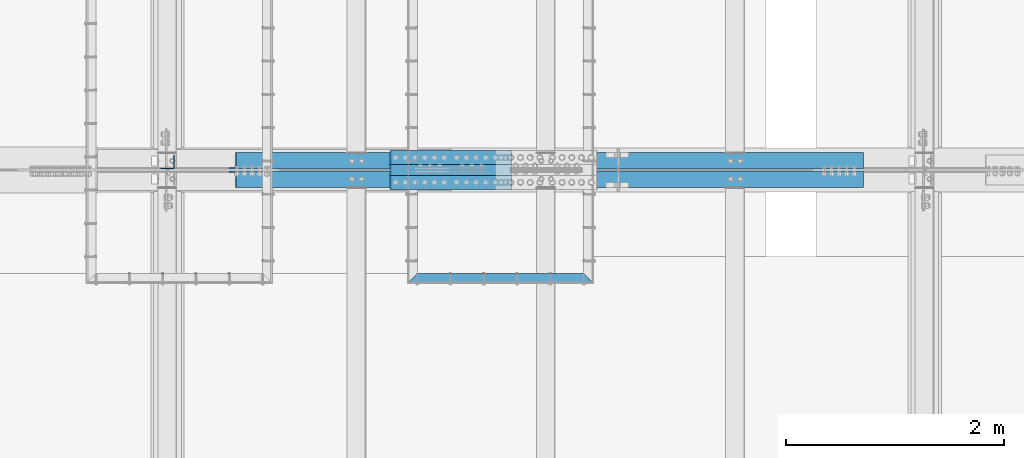
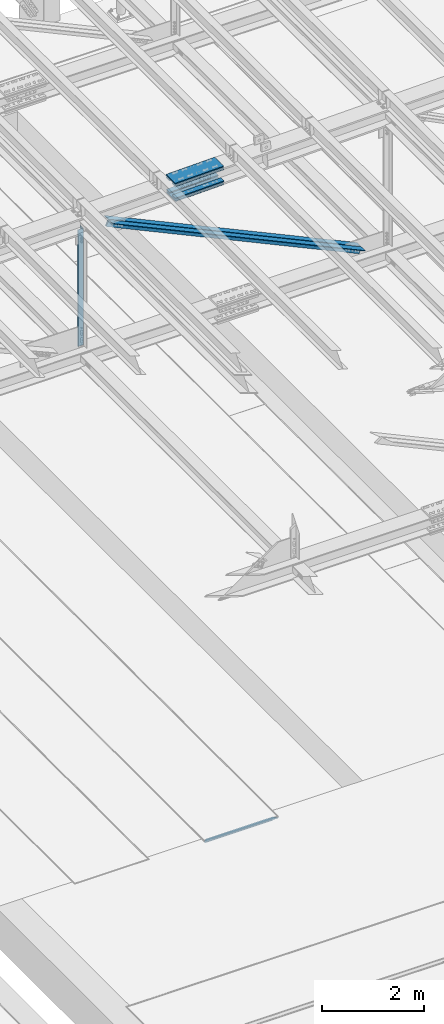
# One storey, part 1890 of 3843: 8 beams, 2 members, 5 elements without a shape of their own.
"""IFC2X3 building model written with IfcOpenShell, lengths in millimetres."""

from ifc_helpers import new_model, si_unit, frame, origin_with_axes, place, context, subcontext, project, spatial, faceted_brep, material, type_object, element, aggregate, save


model = new_model("IFC2X3")

# Units and contexts
model_context = context("Model", 3, precision=1e-05, world=origin_with_axes())
body_context = subcontext(model_context, "Body", "Model", "MODEL_VIEW")
ifc_project = project(units=[si_unit("LENGTHUNIT", "METRE", prefix="MILLI"), si_unit("AREAUNIT", "SQUARE_METRE"), si_unit("VOLUMEUNIT", "CUBIC_METRE"), si_unit("MASSUNIT", "GRAM", prefix="KILO"), si_unit("TIMEUNIT", "SECOND"), si_unit("PLANEANGLEUNIT", "RADIAN"), si_unit("SOLIDANGLEUNIT", "STERADIAN"), si_unit("THERMODYNAMICTEMPERATUREUNIT", "DEGREE_CELSIUS"), si_unit("LUMINOUSINTENSITYUNIT", "LUMEN")], contexts=[model_context])

# Site, building, storey
site_placement = place(None, origin_with_axes())
site = spatial("IfcSite", under=ifc_project, at=site_placement, CompositionType="ELEMENT")
building_placement = place(site_placement, origin_with_axes())
building = spatial("IfcBuilding", under=site, at=building_placement, Name="Undefined", CompositionType="ELEMENT")
storey_placement = place(building_placement, origin_with_axes())
storey = spatial("IfcBuildingStorey", under=building, at=storey_placement, Name="Undefined", CompositionType="ELEMENT", Elevation=0.0)

# Assembly, beam
assembly_1_placement = place(storey_placement, origin_with_axes())
assembly_1 = element("IfcElementAssembly", 1, at=assembly_1_placement, inside=storey, Name="EMBED_ANGLE", AssemblyPlace="NOTDEFINED", PredefinedType="RIGID_FRAME")
ifc_material_1 = material(Name="STEEL/A36")
beam_type_1 = type_object("IfcBeamType", Name="L3-1/2X3-1/2X5/16", PredefinedType="NOTDEFINED")
beam_1_placement = place(assembly_1_placement, frame((51194.525441805, 66281.427, 30410.15), z_axis=(0.0, -1.0, 0.0), x_axis=(1.0, 0.0, 0.0)))
beam_1 = element("IfcBeam", 2, at=beam_1_placement, type_object=beam_type_1, material=ifc_material_1, Name="EMBED_ANGLE", ObjectType="L3-1/2X3-1/2X5/16", context=body_context, shape_type="Brep", body=[
    faceted_brep([(88.8999999971129, 44.4500000000007, -44.4499999999971), (-3.63797880709171e-12, 44.4499999999971, 44.4500000000007), (1701.73653678348, 44.4500000000007, 44.4499999912659), (1612.83653598122, 44.4500000000007, -44.4500000082771), (-3.63797880709171e-12, 36.5124999999971, 44.4500000000007), (1701.73653678348, 36.5125000000007, 44.4499999912659), (80.9624999971129, 36.5125000000007, -36.5124999999971), (1620.77403605285, 36.5125000000007, -36.5125000083208), (80.9624999971129, -44.4500000000007, -36.5124999999971), (1620.77403605285, -44.4500000000007, -36.5125000083208), (88.8999999971129, -44.4500000000007, -44.4499999999971), (1612.83653598122, -44.4500000000007, -44.4500000082771)], [[[0, 1, 2, 3]], [[1, 4, 5, 2]], [[4, 6, 7, 5]], [[6, 8, 9, 7]], [[8, 10, 11, 9]], [[10, 0, 3, 11]], [[5, 7, 9, 11, 3, 2]], [[10, 8, 6, 4, 1, 0]]]),
])
aggregate(assembly_1, [beam_1])

# Assembly, beams
assembly_2_placement = place(storey_placement, origin_with_axes())
assembly_2 = element("IfcElementAssembly", 3, at=assembly_2_placement, inside=storey, Name="BEAM", AssemblyPlace="NOTDEFINED", PredefinedType="RIGID_FRAME")
ifc_material_2 = material(Name="STEEL/A572-50")
beam_type_2 = type_object("IfcBeamType", PredefinedType="NOTDEFINED")
beam_2_placement = place(assembly_2_placement, frame((51036.3131698347, 67386.2, 45743.4514056909), z_axis=(0.0, -1.0, 0.0), x_axis=(0.999702328324067, 0.0, 0.0243978430079076)))
beam_2 = element("IfcBeam", 4, at=beam_2_placement, type_object=beam_type_2, material=ifc_material_2, Name="PLATE", context=body_context, shape_type="Brep", body=[
    faceted_brep([(-4.36557456851006e-11, 12.7000000000116, -63.5), (-4.36557456851006e-11, 12.7000000000116, 63.5), (1104.90000001677, 12.7000000017251, 63.5), (1104.90000001677, 12.7000000017251, -63.5), (1.45519152283669e-11, -12.700000000008, 63.5), (1104.90000001682, -12.6999999982909, 63.5), (1.45519152283669e-11, -12.700000000008, -63.5), (1104.90000001682, -12.6999999982909, -63.5)], [[[0, 1, 2, 3]], [[1, 4, 5, 2]], [[4, 6, 7, 5]], [[6, 0, 3, 7]], [[5, 7, 3, 2]], [[6, 4, 1, 0]]]),
])
beam_3_placement = place(assembly_2_placement, frame((51036.3131698347, 67157.6, 45743.4514056909), z_axis=(0.0, -1.0, 0.0), x_axis=(0.999702328324067, 0.0, 0.0243978430079076)))
beam_3 = element("IfcBeam", 5, at=beam_3_placement, type_object=beam_type_2, material=ifc_material_2, Name="PLATE", context=body_context, shape_type="Brep", body=[
    faceted_brep([(-4.36557456851006e-11, 12.7000000000116, -63.5), (-4.36557456851006e-11, 12.7000000000116, 63.5), (1104.90000001677, 12.7000000017251, 63.5), (1104.90000001677, 12.7000000017251, -63.5), (1.45519152283669e-11, -12.700000000008, 63.5), (1104.90000001682, -12.6999999982909, 63.5), (1.45519152283669e-11, -12.700000000008, -63.5), (1104.90000001682, -12.6999999982909, -63.5)], [[[0, 1, 2, 3]], [[1, 4, 5, 2]], [[4, 6, 7, 5]], [[6, 0, 3, 7]], [[5, 7, 3, 2]], [[6, 4, 1, 0]]]),
])
beam_4_placement = place(assembly_2_placement, frame((51043.5211675553, 67157.6, 45448.2698515432), z_axis=(0.0, -1.0, 0.0), x_axis=(0.999702328324067, 0.0, 0.0243978430079076)))
beam_4 = element("IfcBeam", 6, at=beam_4_placement, type_object=beam_type_2, material=ifc_material_2, Name="PLATE", context=body_context, shape_type="Brep", body=[
    faceted_brep([(-4.36557456851006e-11, 12.7000000000116, -63.5), (-4.36557456851006e-11, 12.7000000000116, 63.5), (1104.90000001677, 12.7000000017251, 63.5), (1104.90000001677, 12.7000000017251, -63.5), (1.45519152283669e-11, -12.700000000008, 63.5), (1104.90000001682, -12.6999999982909, 63.5), (1.45519152283669e-11, -12.700000000008, -63.5), (1104.90000001682, -12.6999999982909, -63.5)], [[[0, 1, 2, 3]], [[1, 4, 5, 2]], [[4, 6, 7, 5]], [[6, 0, 3, 7]], [[5, 7, 3, 2]], [[6, 4, 1, 0]]]),
])
beam_5_placement = place(assembly_2_placement, frame((51043.5211675553, 67386.2, 45448.2698515432), z_axis=(0.0, -1.0, 0.0), x_axis=(0.999702328324067, 0.0, 0.0243978430079076)))
beam_5 = element("IfcBeam", 7, at=beam_5_placement, type_object=beam_type_2, material=ifc_material_2, Name="PLATE", context=body_context, shape_type="Brep", body=[
    faceted_brep([(-4.36557456851006e-11, 12.7000000000116, -63.5), (-4.36557456851006e-11, 12.7000000000116, 63.5), (1104.90000001677, 12.7000000017251, 63.5), (1104.90000001677, 12.7000000017251, -63.5), (1.45519152283669e-11, -12.700000000008, 63.5), (1104.90000001682, -12.6999999982909, 63.5), (1.45519152283669e-11, -12.700000000008, -63.5), (1104.90000001682, -12.6999999982909, -63.5)], [[[0, 1, 2, 3]], [[1, 4, 5, 2]], [[4, 6, 7, 5]], [[6, 0, 3, 7]], [[5, 7, 3, 2]], [[6, 4, 1, 0]]]),
])
beam_type_3 = type_object("IfcBeamType", PredefinedType="NOTDEFINED")
beam_6_placement = place(assembly_2_placement, frame((52139.3758984562, 67271.9, 45832.3806058686), z_axis=(0.0, -1.0, 0.0), x_axis=(-0.999702328324067, 0.0, -0.024397843007905)))
beam_6 = element("IfcBeam", 8, at=beam_6_placement, type_object=beam_type_3, material=ifc_material_2, Name="PLATE", context=body_context, shape_type="Brep", body=[
    faceted_brep([(-1.45519152283669e-11, 12.7000000000025, -177.800000000003), (-1.45519152283669e-11, 12.7000000000025, 177.800000000003), (1104.90000001682, 12.7000000017051, 177.800000000003), (1104.90000001682, 12.7000000017051, -177.800000000003), (4.36557456851006e-11, -12.7000000000171, 177.800000000003), (1104.90000001686, -12.6999999983072, 177.800000000003), (4.36557456851006e-11, -12.7000000000171, -177.800000000003), (1104.90000001686, -12.6999999983072, -177.800000000003)], [[[0, 1, 2, 3]], [[1, 4, 5, 2]], [[4, 6, 7, 5]], [[6, 0, 3, 7]], [[5, 7, 3, 2]], [[6, 4, 1, 0]]]),
])
beam_7_placement = place(assembly_2_placement, frame((52149.6055654215, 67271.9, 45413.3330253169), z_axis=(0.0, -1.0, 0.0), x_axis=(-0.999702328324067, 0.0, -0.024397843007905)))
beam_7 = element("IfcBeam", 9, at=beam_7_placement, type_object=beam_type_3, material=ifc_material_2, Name="PLATE", context=body_context, shape_type="Brep", body=[
    faceted_brep([(-1.45519152283669e-11, 12.7000000000025, -177.800000000003), (-1.45519152283669e-11, 12.7000000000025, 177.800000000003), (1104.90000001682, 12.7000000017051, 177.800000000003), (1104.90000001682, 12.7000000017051, -177.800000000003), (4.36557456851006e-11, -12.7000000000171, 177.800000000003), (1104.90000001686, -12.6999999983072, 177.800000000003), (4.36557456851006e-11, -12.7000000000171, -177.800000000003), (1104.90000001686, -12.6999999983072, -177.800000000003)], [[[0, 1, 2, 3]], [[1, 4, 5, 2]], [[4, 6, 7, 5]], [[6, 0, 3, 7]], [[5, 7, 3, 2]], [[6, 4, 1, 0]]]),
])
aggregate(assembly_2, [beam_2, beam_3, beam_4, beam_6, beam_7, beam_5])

# Assembly, beam
assembly_3_placement = place(storey_placement, origin_with_axes())
assembly_3 = element("IfcElementAssembly", 10, at=assembly_3_placement, inside=storey, Name="ANGLE", AssemblyPlace="NOTDEFINED", PredefinedType="RIGID_FRAME")
beam_type_4 = type_object("IfcBeamType", Name="L5X5X3/8", PredefinedType="NOTDEFINED")
beam_8_placement = place(assembly_3_placement, frame((48996.6, 67344.925, 45545.3859130701), z_axis=(-1.0, 0.0, 0.0), x_axis=(0.0, 0.0, -1.0)))
beam_8 = element("IfcBeam", 11, at=beam_8_placement, type_object=beam_type_4, material=ifc_material_2, Name="ANGLE", ObjectType="L5X5X3/8", context=body_context, shape_type="Brep", body=[
    faceted_brep([(223.333405012316, 63.5, -63.500000000713), (223.333405012323, 63.5, 63.499999999287), (3028.11053135413, 63.5, 63.499999990323), (3028.11053135413, 63.5, -63.500000009677), (223.333405012323, 53.9750000000058, 63.499999999287), (3028.11053135413, 53.9750000000058, 63.499999990323), (223.333405012316, 53.9750000000058, -53.9750000007189), (3028.11053135413, 53.9750000000058, -53.9750000096756), (223.333405012316, -63.5, -53.9750000007189), (3028.11053135413, -63.5, -53.9750000096756), (223.333405012316, -63.5, -63.500000000713), (3028.11053135413, -63.5, -63.500000009677)], [[[0, 1, 2, 3]], [[1, 4, 5, 2]], [[4, 6, 7, 5]], [[6, 8, 9, 7]], [[8, 10, 11, 9]], [[10, 0, 3, 11]], [[5, 7, 9, 11, 3, 2]], [[10, 8, 6, 4, 1, 0]]]),
])
aggregate(assembly_3, [beam_8])

# Assembly, member
assembly_4_placement = place(storey_placement, origin_with_axes())
assembly_4 = element("IfcElementAssembly", 12, at=assembly_4_placement, inside=storey, Name="ANGLE", AssemblyPlace="NOTDEFINED", PredefinedType="RIGID_FRAME")
member_type = type_object("IfcMemberType", Name="L6X6X1/2", PredefinedType="NOTDEFINED")
member_1_placement = place(assembly_4_placement, frame((48996.6000000179, 67357.625, 45545.3859130701), z_axis=(-0.42077460682524, 0.0, -0.907165216623226), x_axis=(0.907165216623227, 0.0, -0.420774606825239)))
member_1 = element("IfcMember", 13, at=member_1_placement, type_object=member_type, material=ifc_material_2, Name="ANGLE", ObjectType="L6X6X1/2", context=body_context, shape_type="Brep", body=[
    faceted_brep([(654.507159665402, 76.1999999999971, -76.1999999988329), (654.507159665405, 76.1999999999971, 76.2000000014305), (6988.96829896515, 76.1999999999971, 76.200000013916), (6988.96829896514, 76.1999999999971, -76.1999999863401), (654.507159665405, 63.5, 76.2000000014305), (6988.96829896515, 63.5, 76.200000013916), (654.507159665402, 63.5, -63.499999998814), (6988.96829896515, 63.5, -63.4999999863212), (654.507159665402, -76.1999999999971, -63.499999998814), (6988.96829896515, -76.1999999999971, -63.4999999863212), (654.507159665402, -76.1999999999971, -76.1999999988329), (6988.96829896514, -76.1999999999971, -76.1999999863401)], [[[0, 1, 2, 3]], [[1, 4, 5, 2]], [[4, 6, 7, 5]], [[6, 8, 9, 7]], [[8, 10, 11, 9]], [[10, 0, 3, 11]], [[5, 7, 9, 11, 3, 2]], [[10, 8, 6, 4, 1, 0]]]),
])
aggregate(assembly_4, [member_1])

assembly_5_placement = place(storey_placement, origin_with_axes())
assembly_5 = element("IfcElementAssembly", 14, at=assembly_5_placement, inside=storey, Name="ANGLE", AssemblyPlace="NOTDEFINED", PredefinedType="RIGID_FRAME")
member_2_placement = place(assembly_5_placement, frame((55930.7999999715, 67186.175, 42329.0640927459), z_axis=(-0.42077460682524, 0.0, -0.907165216623226), x_axis=(-0.907165216623227, 0.0, 0.420774606825239)))
member_2 = element("IfcMember", 15, at=member_2_placement, type_object=member_type, material=ifc_material_2, Name="ANGLE", ObjectType="L6X6X1/2", context=body_context, shape_type="Brep", body=[
    faceted_brep([(654.843295498635, 76.1999999999971, -76.2000000014159), (654.843295498642, 76.1999999999971, 76.1999999988402), (6989.30443479839, 76.1999999999971, 76.1999999863547), (6989.30443479839, 76.1999999999971, -76.200000013916), (654.843295498642, 63.5, 76.1999999988402), (6989.30443479839, 63.5, 76.1999999863547), (654.843295498638, 63.5, -63.5000000014043), (6989.30443479839, 63.5, -63.5000000138898), (654.843295498638, -76.1999999999971, -63.5000000014043), (6989.30443479839, -76.1999999999971, -63.5000000138898), (654.843295498635, -76.1999999999971, -76.2000000014159), (6989.30443479839, -76.1999999999971, -76.200000013916)], [[[0, 1, 2, 3]], [[1, 4, 5, 2]], [[4, 6, 7, 5]], [[6, 8, 9, 7]], [[8, 10, 11, 9]], [[10, 0, 3, 11]], [[5, 7, 9, 11, 3, 2]], [[10, 8, 6, 4, 1, 0]]]),
])
aggregate(assembly_5, [member_2])

save(model, "model.ifc")
